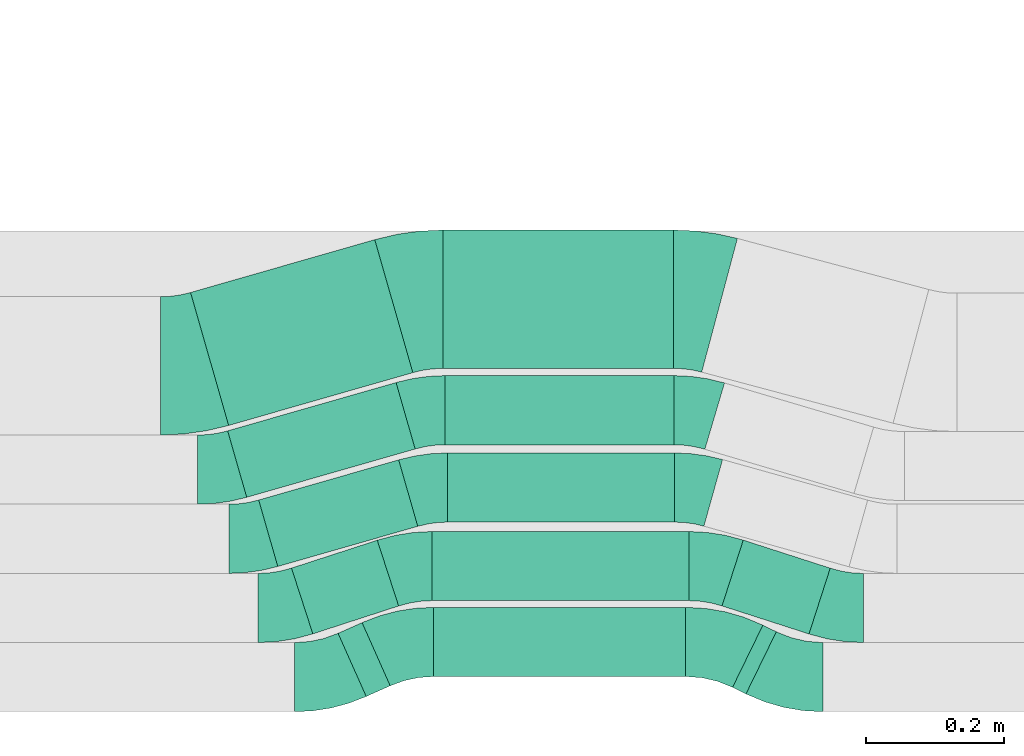
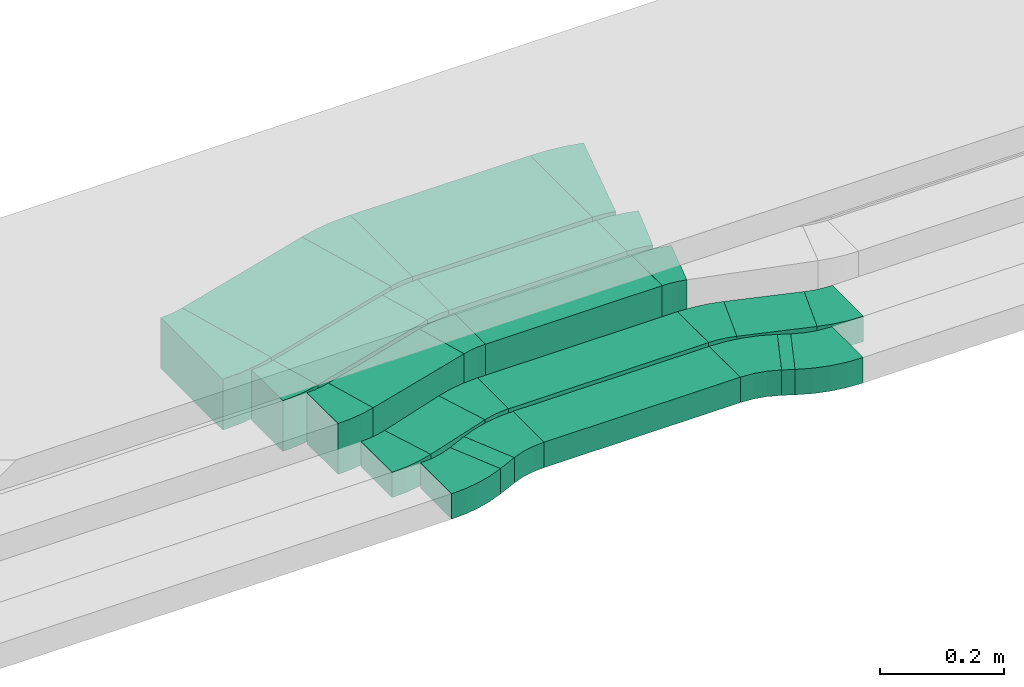
# One storey, part 22 of 38: 17 flow fittings, 12 flow segments.
"""IFC2X3 building model written with IfcOpenShell, lengths in millimetres."""

import ifcopenshell
import ifcopenshell.guid

model = None  # the IFC model being written
_history = None  # IfcOwnerHistory: only IFC2X3 demands one
_inside = {}  # id of a spatial element -> (the spatial element, [elements in it])
_under = {}  # id of a project, library or spatial element -> (it, [spatial elements below it])
_declared = {}  # id of a project -> (the project, [libraries it declares])
_typed = {}  # id of a type object -> (the type object, [elements of that type])
_made_of = {}  # id of a material, layer set ... -> (it, [elements and type objects made of it])


def new_model(schema):
    """Start an empty IFC model of exactly this schema.

    Asked for "IFC4X3", IfcOpenShell would pick the latest addendum, in which some entities
    have other attributes; the version numbers below select the first issue.
    IFC2X3 requires an IfcOwnerHistory on every rooted entity: one is made here for all.
    """
    global model, _history
    if schema == "IFC4X3":
        model = ifcopenshell.file(schema_version=(4, 3, 0, 0))
    else:
        model = ifcopenshell.file(schema=schema)
    _inside.clear()
    _under.clear()
    _declared.clear()
    _typed.clear()
    _made_of.clear()
    _history = None
    if model.schema == "IFC2X3":
        org = make("IfcOrganization", Name="unknown")
        user = make(
            "IfcPersonAndOrganization",
            ThePerson=make("IfcPerson", FamilyName="unknown"),
            TheOrganization=org,
        )
        app = make(
            "IfcApplication",
            ApplicationDeveloper=org,
            Version="unknown",
            ApplicationFullName="unknown",
            ApplicationIdentifier="unknown",
        )
        _history = make(
            "IfcOwnerHistory",
            OwningUser=user,
            OwningApplication=app,
            ChangeAction="ADDED",
            CreationDate=0,
        )
    return model


def make(cls, **values):
    """One entity of the class cls with the attributes given. An attribute that is None is left unset."""
    return model.create_entity(
        cls, **{name: value for name, value in values.items() if value is not None}
    )


def entity(cls, *values):
    """Any entity or typed value of the class cls, its attributes in the order of the schema. None: left unset."""
    e = model.create_entity(cls)
    for i, value in enumerate(values):
        if value is not None:
            e[i] = value
    return e


def rooted(cls, **values):
    """An entity with a GlobalId (a new one), such as an element, a storey or a relation."""
    return make(cls, GlobalId=ifcopenshell.guid.new(), OwnerHistory=_history, **values)


def si_unit(unit_type, name, prefix=None):
    """IfcSIUnit, for example si_unit("LENGTHUNIT", "METRE", prefix="MILLI")."""
    return make("IfcSIUnit", UnitType=unit_type, Prefix=prefix, Name=name)


def converted_unit(unit_type, name, factor, base, dimensions=None, offset=None):
    """IfcConversionBasedUnit, such as the inch: factor (a typed value) times the base unit."""
    return make(
        "IfcConversionBasedUnit"
        if offset is None
        else "IfcConversionBasedUnitWithOffset",
        ConversionOffset=offset,
        Dimensions=None
        if dimensions is None
        else entity("IfcDimensionalExponents", *dimensions),
        UnitType=unit_type,
        Name=name,
        ConversionFactor=make(
            "IfcMeasureWithUnit", ValueComponent=factor, UnitComponent=base
        ),
    )


def derived_unit(unit_type, elements):
    """IfcDerivedUnit: a product of units, each with its exponent."""
    return make(
        "IfcDerivedUnit",
        Elements=[
            make("IfcDerivedUnitElement", Unit=unit, Exponent=power)
            for unit, power in elements
        ],
        UnitType=unit_type,
    )


def assignment(units):
    """IfcUnitAssignment: the units of a project."""
    return None if units is None else make("IfcUnitAssignment", Units=units)


def point(xyz):
    """IfcCartesianPoint."""
    return None if xyz is None else make("IfcCartesianPoint", Coordinates=xyz)


def direction(xyz):
    """IfcDirection."""
    return None if xyz is None else make("IfcDirection", DirectionRatios=xyz)


def frame(location, z_axis=None, x_axis=None):
    """IfcAxis2Placement3D, a coordinate frame: its origin and axes. An axis left out is left unset."""
    return make(
        "IfcAxis2Placement3D",
        Location=point(location),
        Axis=direction(z_axis),
        RefDirection=direction(x_axis),
    )


def frame_2d(location, x_axis=None):
    """IfcAxis2Placement2D, a coordinate frame in the plane: its origin and x axis."""
    return make(
        "IfcAxis2Placement2D", Location=point(location), RefDirection=direction(x_axis)
    )


def origin():
    """The frame at (0, 0, 0) with its axes left unset."""
    return frame((0.0, 0.0, 0.0))


def place(relative_to, where):
    """IfcLocalPlacement: puts the frame where relative to a parent placement (None: the world)."""
    return make(
        "IfcLocalPlacement", PlacementRelTo=relative_to, RelativePlacement=where
    )


def context(
    kind, dimensions, precision=None, world=None, true_north=None, identifier=None
):
    """IfcGeometricRepresentationContext, for example the 3D "Model" context."""
    return make(
        "IfcGeometricRepresentationContext",
        ContextIdentifier=identifier,
        ContextType=kind,
        CoordinateSpaceDimension=dimensions,
        Precision=precision,
        WorldCoordinateSystem=world,
        TrueNorth=true_north,
    )


def subcontext(parent, identifier, kind, view, scale=None):
    """IfcGeometricRepresentationSubContext, for example "Body" below "Model"."""
    return make(
        "IfcGeometricRepresentationSubContext",
        ContextIdentifier=identifier,
        ContextType=kind,
        ParentContext=parent,
        TargetScale=scale,
        TargetView=view,
    )


def project(units=None, contexts=None):
    """IfcProject with its units and contexts."""
    return rooted(
        "IfcProject",
        Name="project",
        RepresentationContexts=contexts,
        UnitsInContext=assignment(units),
    )


def spatial(cls, under=None, at=None, **own):
    """A site, building, storey or space (cls), placed at a placement, below another one or the project."""
    s = rooted(cls, ObjectPlacement=at, **own)
    if under is not None:
        _under.setdefault(under.id(), (under, []))[1].append(s)
    return s


def polyline(points):
    """IfcPolyline through the points."""
    return make("IfcPolyline", Points=[point(p) for p in points])


def circle_curve(where, radius):
    """IfcCircle in the frame where."""
    return make("IfcCircle", Position=where, Radius=radius)


def parameter(value):
    """IfcParameterValue: where a trimmed curve begins or ends, as a parameter of its basis curve."""
    return model.create_entity("IfcParameterValue", value)


def trimmed(basis, trim1, trim2, sense, master):
    """IfcTrimmedCurve: the piece of a basis curve between two trims."""
    return make(
        "IfcTrimmedCurve",
        BasisCurve=basis,
        Trim1=trim1,
        Trim2=trim2,
        SenseAgreement=sense,
        MasterRepresentation=master,
    )


def segment(curve, same_sense, transition):
    """IfcCompositeCurveSegment."""
    return make(
        "IfcCompositeCurveSegment",
        Transition=transition,
        SameSense=same_sense,
        ParentCurve=curve,
    )


def composite_curve(segments, self_intersect=None):
    """IfcCompositeCurve: segments joined end to end."""
    return make("IfcCompositeCurve", Segments=segments, SelfIntersect=self_intersect)


def profile(cls, at=None, kind="AREA", **sizes):
    """A parametric profile (cls). Its sizes go by their IFC names, for example OverallWidth=200.0."""
    return make(cls, ProfileType=kind, Position=at, **sizes)


def rectangle(**sizes):
    """IfcRectangleProfileDef."""
    return profile("IfcRectangleProfileDef", **sizes)


def outline(outer, holes=None, kind="AREA"):
    """IfcArbitraryClosedProfileDef: a profile drawn as a closed curve; with holes, ...WithVoids."""
    if holes is None:
        return make("IfcArbitraryClosedProfileDef", ProfileType=kind, OuterCurve=outer)
    return make(
        "IfcArbitraryProfileDefWithVoids",
        ProfileType=kind,
        OuterCurve=outer,
        InnerCurves=holes,
    )


def extrude(swept, where, along, depth):
    """IfcExtrudedAreaSolid: the profile swept, set in the frame where, extruded along a direction by depth."""
    return make(
        "IfcExtrudedAreaSolid",
        SweptArea=swept,
        Position=where,
        ExtrudedDirection=direction(along),
        Depth=depth,
    )


def shape(context_of_items, identifier, shape_type, items):
    """IfcShapeRepresentation: the items that make up one representation, for example the "Body"."""
    return make(
        "IfcShapeRepresentation",
        ContextOfItems=context_of_items,
        RepresentationIdentifier=identifier,
        RepresentationType=shape_type,
        Items=items,
    )


def source(mapping_origin, context_of_items, identifier, shape_type, items):
    """IfcRepresentationMap: a shape defined once, which mapped items show again and again."""
    return make(
        "IfcRepresentationMap",
        MappingOrigin=mapping_origin,
        MappedRepresentation=shape(context_of_items, identifier, shape_type, items),
    )


def transform(
    local_origin,
    x_axis=None,
    y_axis=None,
    z_axis=None,
    scale=None,
    scale2=None,
    scale3=None,
    uniform=True,
):
    """IfcCartesianTransformationOperator3D, or its non-uniform kind. x_axis, y_axis, z_axis: its Axis1, 2, 3."""
    if uniform:
        return make(
            "IfcCartesianTransformationOperator3D",
            Axis1=direction(x_axis),
            Axis2=direction(y_axis),
            LocalOrigin=point(local_origin),
            Scale=scale,
            Axis3=direction(z_axis),
        )
    return make(
        "IfcCartesianTransformationOperator3DnonUniform",
        Axis1=direction(x_axis),
        Axis2=direction(y_axis),
        LocalOrigin=point(local_origin),
        Scale=scale,
        Axis3=direction(z_axis),
        Scale2=scale2,
        Scale3=scale3,
    )


def mapped(mapping_source, mapping_target):
    """IfcMappedItem: shows the shape of a source again, moved by a transform."""
    return make(
        "IfcMappedItem", MappingSource=mapping_source, MappingTarget=mapping_target
    )


def material(Name=None, Category=None):
    """IfcMaterial."""
    return make("IfcMaterial", Name=Name, Category=Category)


def made_of(thing, what):
    """Note that an element or type object is made of a material, layer set ...; save() writes the relation."""
    if what is not None:
        _made_of.setdefault(what.id(), (what, []))[1].append(thing)
    return thing


def type_object(cls, material=None, **own):
    """A type object (cls), such as IfcWallType, which elements share."""
    return made_of(rooted(cls, **own), material)


def type_shapes(of_type, sources):
    """Give a type object the sources (RepresentationMaps) that its elements show as mapped items."""
    of_type.RepresentationMaps = sources


def element(
    cls,
    number,
    at=None,
    inside=None,
    cuts=None,
    type_object=None,
    material=None,
    context=None,
    identifier="Body",
    shape_type=None,
    held_by="IfcProductDefinitionShape",
    body=None,
    shapes=None,
    **own,
):
    """One element of the class cls, such as IfcWall. Its Tag is "e" and its number.

    at: its placement. inside: the storey or other place that contains it. cuts: it is an
    opening in that element (IfcRelVoidsElement). A single representation is given by context,
    identifier, shape_type and body (its items); several are given by shapes. held_by: the class
    of the entity that holds the representations. save() writes the other relations.
    """
    e = rooted(cls, Tag="e%d" % number, ObjectPlacement=at, **own)
    if body is not None:
        shapes = [shape(context, identifier, shape_type, body)]
    if shapes is not None:
        e.Representation = make(held_by, Representations=shapes)
    if inside is not None:
        _inside.setdefault(inside.id(), (inside, []))[1].append(e)
    if cuts is not None:
        rooted(
            "IfcRelVoidsElement", RelatingBuildingElement=cuts, RelatedOpeningElement=e
        )
    if type_object is not None:
        _typed.setdefault(type_object.id(), (type_object, []))[1].append(e)
    return made_of(e, material)


def aggregate(whole, parts):
    """IfcRelAggregates: a whole, such as a stair, and the parts it consists of."""
    return rooted("IfcRelAggregates", RelatingObject=whole, RelatedObjects=parts)


def save(model, path):
    """Write the relations noted so far, then the file.

    IfcRelAggregates (storeys below a building ...), IfcRelContainedInSpatialStructure (elements
    in a storey), IfcRelDefinesByType, IfcRelAssociatesMaterial and IfcRelDeclares: one each for
    every whole, place, type object, material and project.
    """
    for whole, parts in _under.values():
        aggregate(whole, parts)
    for where, things in _inside.values():
        rooted(
            "IfcRelContainedInSpatialStructure",
            RelatedElements=things,
            RelatingStructure=where,
        )
    for kind, things in _typed.values():
        rooted("IfcRelDefinesByType", RelatedObjects=things, RelatingType=kind)
    for what, things in _made_of.values():
        rooted("IfcRelAssociatesMaterial", RelatedObjects=things, RelatingMaterial=what)
    for by, libraries in _declared.values():
        rooted("IfcRelDeclares", RelatingContext=by, RelatedDefinitions=libraries)
    model.write(path)


model = new_model("IFC2X3")

# Units and contexts
model_context = context("Model", 3, precision=0.01, world=origin(), true_north=direction((6.12303176911189e-17, 1.0)))
body_context = subcontext(model_context, "Body", "Model", "MODEL_VIEW")
ifc_project = project(units=[si_unit("LENGTHUNIT", "METRE", prefix="MILLI"), si_unit("AREAUNIT", "SQUARE_METRE"), si_unit("VOLUMEUNIT", "CUBIC_METRE"), converted_unit("PLANEANGLEUNIT", "DEGREE", entity("IfcRatioMeasure", 0.0174532925199433), si_unit("PLANEANGLEUNIT", "RADIAN"), dimensions=[0, 0, 0, 0, 0, 0, 0]), si_unit("MASSUNIT", "GRAM", prefix="KILO"), derived_unit("MASSDENSITYUNIT", [(si_unit("MASSUNIT", "GRAM", prefix="KILO"), 1), (si_unit("LENGTHUNIT", "METRE"), -3)]), derived_unit("MOMENTOFINERTIAUNIT", [(si_unit("LENGTHUNIT", "METRE"), 4)]), si_unit("TIMEUNIT", "SECOND"), si_unit("FREQUENCYUNIT", "HERTZ"), si_unit("THERMODYNAMICTEMPERATUREUNIT", "DEGREE_CELSIUS"), derived_unit("THERMALTRANSMITTANCEUNIT", [(si_unit("MASSUNIT", "GRAM", prefix="KILO"), 1), (si_unit("THERMODYNAMICTEMPERATUREUNIT", "KELVIN"), -1), (si_unit("TIMEUNIT", "SECOND"), -3)]), derived_unit("VOLUMETRICFLOWRATEUNIT", [(si_unit("LENGTHUNIT", "METRE"), 3), (si_unit("TIMEUNIT", "SECOND"), -1)]), derived_unit("MASSFLOWRATEUNIT", [(si_unit("MASSUNIT", "GRAM", prefix="KILO"), 1), (si_unit("TIMEUNIT", "SECOND"), -1)]), derived_unit("ROTATIONALFREQUENCYUNIT", [(si_unit("TIMEUNIT", "SECOND"), -1)]), si_unit("ELECTRICCURRENTUNIT", "AMPERE"), si_unit("ELECTRICVOLTAGEUNIT", "VOLT"), si_unit("POWERUNIT", "WATT"), si_unit("FORCEUNIT", "NEWTON", prefix="KILO"), si_unit("ILLUMINANCEUNIT", "LUX"), si_unit("LUMINOUSFLUXUNIT", "LUMEN"), si_unit("LUMINOUSINTENSITYUNIT", "CANDELA"), derived_unit("USERDEFINED", [(si_unit("MASSUNIT", "GRAM", prefix="KILO"), -1), (si_unit("LENGTHUNIT", "METRE"), -2), (si_unit("TIMEUNIT", "SECOND"), 3), (si_unit("LUMINOUSFLUXUNIT", "LUMEN"), 1)]), derived_unit("LINEARVELOCITYUNIT", [(si_unit("LENGTHUNIT", "METRE"), 1), (si_unit("TIMEUNIT", "SECOND"), -1)]), si_unit("PRESSUREUNIT", "PASCAL"), derived_unit("USERDEFINED", [(si_unit("LENGTHUNIT", "METRE"), -2), (si_unit("MASSUNIT", "GRAM", prefix="KILO"), 1), (si_unit("TIMEUNIT", "SECOND"), -2)]), derived_unit("LINEARFORCEUNIT", [(si_unit("MASSUNIT", "GRAM", prefix="KILO"), 1), (si_unit("LENGTHUNIT", "METRE"), 1), (si_unit("TIMEUNIT", "SECOND"), -2), (si_unit("LENGTHUNIT", "METRE"), -1)]), derived_unit("PLANARFORCEUNIT", [(si_unit("MASSUNIT", "GRAM", prefix="KILO"), 1), (si_unit("LENGTHUNIT", "METRE"), 1), (si_unit("TIMEUNIT", "SECOND"), -2), (si_unit("LENGTHUNIT", "METRE"), -2)])], contexts=[model_context])

# Site, building, storey
site_placement = place(None, frame((0.0, -0.00077364408347762, 0.0)))
site = spatial("IfcSite", under=ifc_project, at=site_placement, CompositionType="ELEMENT")
building_placement = place(site_placement, origin())
building = spatial("IfcBuilding", under=site, at=building_placement, CompositionType="ELEMENT")
storey_placement = place(building_placement, frame((0.0, 0.0, 4200.0)))
storey = spatial("IfcBuildingStorey", under=building, at=storey_placement, CompositionType="ELEMENT", Elevation=4200.0)

# Flow segments
cable_carrier_segment_type = type_object("IfcCableCarrierSegmentType", PredefinedType="CABLETRAYSEGMENT")
flow_segment_1_placement = place(storey_placement, frame((34682.2954440564, 268.677374504435, 2836.0)))
element("IfcFlowSegment", 1, at=flow_segment_1_placement, inside=storey, type_object=cable_carrier_segment_type, context=body_context, shape_type="SweptSolid", body=[
    extrude(rectangle(XDim=37.9773753319745, YDim=100.000000000002, at=frame_2d((3.96305210870196e-12, -1.74793512996985e-12), x_axis=(1.0, 0.0))), frame((37.6838615176679, 53.4006679598074, 0.0), z_axis=(0.0, 0.0, 1.0), x_axis=(0.913545457642342, 0.406736643076381, 0.0)), (0.0, 0.0, 1.0), 49.9999999999995),
])
flow_segment_2_placement = place(storey_placement, frame((34820.5872090108, 297.499082656489, 2836.0)))
element("IfcFlowSegment", 2, at=flow_segment_2_placement, inside=storey, type_object=cable_carrier_segment_type, context=body_context, shape_type="SweptSolid", body=[
    extrude(rectangle(XDim=364.315049440889, YDim=100.0, at=frame_2d((0.0, -3.19744231092045e-14), x_axis=(1.0, 0.0))), frame((182.157524720444, 50.0, 0.0)), (0.0, 0.0, 1.0), 49.9999999999995),
])
flow_segment_3_placement = place(storey_placement, frame((35252.5567245163, 272.396861844019, 2836.0)))
element("IfcFlowSegment", 3, at=flow_segment_3_placement, inside=storey, type_object=cable_carrier_segment_type, context=body_context, shape_type="SweptSolid", body=[
    extrude(rectangle(XDim=21.632255407363, YDim=99.9999999999977, at=frame_2d((-1.94066984704477e-12, -9.66338120633736e-13), x_axis=(1.0, 0.0))), frame((31.6400285235472, 49.6811806202314, 0.0), z_axis=(0.0, 0.0, 1.0), x_axis=(-0.898794046298938, 0.438371146789548, 0.0)), (0.0, 0.0, 1.0), 49.9999999999995),
])
flow_segment_4_placement = place(storey_placement, frame((34614.9489776385, 359.201890192537, 2836.0)))
element("IfcFlowSegment", 4, at=flow_segment_4_placement, inside=storey, type_object=cable_carrier_segment_type, context=body_context, shape_type="SweptSolid", body=[
    extrude(rectangle(XDim=130.375714038921, YDim=100.0, at=frame_2d((-7.105427357601e-15, -2.8421709430404e-14), x_axis=(1.0, 0.0))), frame((77.4481859204265, 67.696981460663, 0.0), z_axis=(0.0, 0.0, 1.0), x_axis=(0.951056516295102, 0.309016994375106, 0.0)), (0.0, 0.0, 1.0), 49.9999999999995),
])
flow_segment_5_placement = place(storey_placement, frame((34818.1489551518, 407.140741034452, 2836.0)))
element("IfcFlowSegment", 5, at=flow_segment_5_placement, inside=storey, type_object=cable_carrier_segment_type, context=body_context, shape_type="SweptSolid", body=[
    extrude(rectangle(XDim=371.2003762548, YDim=100.0, at=frame_2d((0.0, -3.19744231092045e-14), x_axis=(1.0, 0.0))), frame((185.6001881274, 50.0, 0.0)), (0.0, 0.0, 1.0), 49.9999999999995),
])
flow_segment_6_placement = place(storey_placement, frame((35237.3479071855, 359.034914354499, 2836.0)))
element("IfcFlowSegment", 6, at=flow_segment_6_placement, inside=storey, type_object=cable_carrier_segment_type, context=body_context, shape_type="SweptSolid", body=[
    extrude(rectangle(XDim=132.114181843629, YDim=99.9999999999975, at=frame_2d((1.4210854715202e-14, -2.8421709430404e-14), x_axis=(1.0, 0.0))), frame((78.2165612123092, 67.8639572987042, 0.0), z_axis=(0.0, 0.0, 1.0), x_axis=(-0.951716267923426, 0.306979063406458, 0.0)), (0.0, 0.0, 1.0), 49.9999999999995),
])
flow_segment_7_placement = place(storey_placement, frame((34567.5571030409, 456.617215643251, 2836.0)))
element("IfcFlowSegment", 7, at=flow_segment_7_placement, inside=storey, type_object=cable_carrier_segment_type, context=body_context, shape_type="SweptSolid", body=[
    extrude(rectangle(XDim=210.504113333605, YDim=100.000000000001, at=frame_2d((-2.1316282072803e-14, -6.3948846218409e-14), x_axis=(1.0, 0.0))), frame((114.956638283379, 77.0744833908625, 0.0), z_axis=(0.0, 0.0, 1.0), x_axis=(0.961261695938295, 0.275637355817084, 0.0)), (0.0, 0.0, 1.0), 100.000000000001),
])
flow_segment_8_placement = place(storey_placement, frame((34840.7772446761, 520.726395796214, 2836.0)))
element("IfcFlowSegment", 8, at=flow_segment_8_placement, inside=storey, type_object=cable_carrier_segment_type, context=body_context, shape_type="SweptSolid", body=[
    extrude(rectangle(XDim=328.015010459565, YDim=100.0, at=frame_2d((2.17426077142591e-12, -6.75015598972095e-14), x_axis=(1.0, 0.0))), frame((164.007505229785, 50.0, 0.0)), (0.0, 0.0, 1.0), 100.000000000001),
])
flow_segment_9_placement = place(storey_placement, frame((34522.6611141016, 556.617215643282, 2836.0)))
element("IfcFlowSegment", 9, at=flow_segment_9_placement, inside=storey, type_object=cable_carrier_segment_type, context=body_context, shape_type="SweptSolid", body=[
    extrude(rectangle(XDim=253.294448744535, YDim=99.9999999999999, at=frame_2d((2.08189021577709e-12, -5.89750470680883e-13), x_axis=(1.0, 0.0))), frame((135.522993476812, 82.971790844471, 0.0), z_axis=(0.0, 0.0, 1.0), x_axis=(0.961261695938265, 0.275637355817187, 0.0)), (0.0, 0.0, 1.0), 100.000000000001),
])
flow_segment_10_placement = place(storey_placement, frame((34837.0139661237, 632.521010703464, 2836.0)))
element("IfcFlowSegment", 10, at=flow_segment_10_placement, inside=storey, type_object=cable_carrier_segment_type, context=body_context, shape_type="SweptSolid", body=[
    extrude(rectangle(XDim=331.015908531008, YDim=100.0, at=frame_2d((2.17426077142591e-12, 0.0), x_axis=(1.0, 0.0))), frame((165.507954265502, 50.0, 0.0)), (0.0, 0.0, 1.0), 100.000000000001),
])
flow_segment_11_placement = place(storey_placement, frame((34468.9939164237, 660.49104604952, 2836.0)))
element("IfcFlowSegment", 11, at=flow_segment_11_placement, inside=storey, type_object=cable_carrier_segment_type, context=body_context, shape_type="SweptSolid", body=[
    extrude(rectangle(XDim=277.030700685204, YDim=200.000000000003, at=frame_2d((-2.06057393370429e-12, 6.46593889541691e-13), x_axis=(1.0, 0.0))), frame((160.713236165529, 134.306174502351, 0.0), z_axis=(0.0, 0.0, 1.0), x_axis=(0.961261695938271, 0.275637355817165, 0.0)), (0.0, 0.0, 1.0), 100.000000000001),
])
flow_segment_12_placement = place(storey_placement, frame((34833.7272538232, 742.937438831638, 2836.0)))
element("IfcFlowSegment", 12, at=flow_segment_12_placement, inside=storey, type_object=cable_carrier_segment_type, context=body_context, shape_type="SweptSolid", body=[
    extrude(rectangle(XDim=333.654743209258, YDim=200.0, at=frame_2d((0.0, 6.3948846218409e-14), x_axis=(1.0, 0.0))), frame((166.827371604629, 100.0, 0.0)), (0.0, 0.0, 1.0), 100.000000000001),
])

# Flow fittings
ifc_material = material()
cable_carrier_fitting_type_1 = type_object("IfcCableCarrierFittingType", Name="470_DKC_S5_Variable Angle Elbow 0-45:-", PredefinedType="NOTDEFINED", material=ifc_material)
shared_shape_1 = source(origin(), body_context, "Body", "SweptSolid", [
    extrude(outline(composite_curve([segment(polyline([(-28.5540510056852, -53.9427397451227), (-27.5540510056839, -53.9427397451227)]), True, "CONTINUOUS"), segment(trimmed(circle_curve(frame_2d((-27.5540510056865, 196.057260254877), x_axis=(0.0, -1.0)), 250.0), [parameter(0.0)], [parameter(16.0000000000001)], True, "PARAMETER"), True, "CONTINUOUS"), segment(polyline([(41.3552879485661, -44.2581637297016), (42.3165496445045, -43.9825263738845)]), True, "CONTINUOUS"), segment(polyline([(42.3165496445045, -43.9825263738846), (14.7528140628032, 52.1436432199469)]), True, "CONTINUOUS"), segment(polyline([(14.7528140628032, 52.1436432199469), (13.791552366865, 51.8680058641299)]), True, "CONTINUOUS"), segment(trimmed(circle_curve(frame_2d((-27.5540510056865, 196.057260254877), x_axis=(0.0, -1.0)), 150.0), [parameter(0.0)], [parameter(16.0000000000001)], True, "PARAMETER"), False, "CONTINUOUS"), segment(polyline([(-27.5540510056847, 46.0572602548772), (-28.5540510056861, 46.0572602548772)]), True, "CONTINUOUS"), segment(polyline([(-28.5540510056861, 46.0572602548772), (-28.5540510056852, -53.9427397451227)]), True, "CONTINUOUS")], self_intersect=False)), frame((-0.554115934784018, 3.94273974511436, -50.0)), (0.0, 0.0, 1.0), 100.0),
])
type_shapes(cable_carrier_fitting_type_1, [shared_shape_1])
flow_fitting_1_placement = place(storey_placement, frame((34553.3584049129, 496.65700227203, 2886.0)))
element("IfcFlowFitting", 13, at=flow_fitting_1_placement, inside=storey, type_object=cable_carrier_fitting_type_1, material=ifc_material, Name="470_DKC_S5_Variable Angle Elbow 0-45:-", ObjectType="470_DKC_S5_Variable Angle Elbow 0-45:-", context=body_context, shape_type="MappedRepresentation", body=[
    mapped(shared_shape_1, transform((0.0, 0.0, 0.0), scale=1.0)),
])
flow_fitting_2_placement = place(storey_placement, frame((34811.6690777356, 570.726395796198, 2886.0), z_axis=(0.0, 0.0, 1.0), x_axis=(-1.0, 0.0, 0.0)))
element("IfcFlowFitting", 14, at=flow_fitting_2_placement, inside=storey, type_object=cable_carrier_fitting_type_1, material=ifc_material, Name="470_DKC_S5_Variable Angle Elbow 0-45:-", ObjectType="470_DKC_S5_Variable Angle Elbow 0-45:-", context=body_context, shape_type="MappedRepresentation", body=[
    mapped(shared_shape_1, transform((0.0, 0.0, 0.0), scale=1.0)),
])
flow_fitting_3_placement = place(storey_placement, frame((34508.4624159736, 596.657002272058, 2886.0)))
element("IfcFlowFitting", 15, at=flow_fitting_3_placement, inside=storey, type_object=cable_carrier_fitting_type_1, material=ifc_material, Name="470_DKC_S5_Variable Angle Elbow 0-45:-", ObjectType="470_DKC_S5_Variable Angle Elbow 0-45:-", context=body_context, shape_type="MappedRepresentation", body=[
    mapped(shared_shape_1, transform((0.0, 0.0, 0.0), scale=1.0)),
])
flow_fitting_4_placement = place(storey_placement, frame((34807.9057991832, 682.521010703447, 2886.0), z_axis=(0.0, 0.0, 1.0), x_axis=(-1.0, 0.0, 0.0)))
element("IfcFlowFitting", 16, at=flow_fitting_4_placement, inside=storey, type_object=cable_carrier_fitting_type_1, material=ifc_material, Name="470_DKC_S5_Variable Angle Elbow 0-45:-", ObjectType="470_DKC_S5_Variable Angle Elbow 0-45:-", context=body_context, shape_type="MappedRepresentation", body=[
    mapped(shared_shape_1, transform((0.0, 0.0, 0.0), scale=1.0)),
])
cable_carrier_fitting_type_2 = type_object("IfcCableCarrierFittingType", Name="470_DKC_S5_Variable Angle Elbow 0-45:-", PredefinedType="NOTDEFINED", material=ifc_material)
shared_shape_2 = source(origin(), body_context, "Body", "SweptSolid", [
    extrude(outline(composite_curve([segment(polyline([(-41.6520506719925, -58.7471383965093), (-40.6520506719912, -58.7471383965093)]), True, "CONTINUOUS"), segment(trimmed(circle_curve(frame_2d((-40.6520506719917, 191.25286160349), x_axis=(0.0, -1.0)), 250.0), [parameter(0.0)], [parameter(24.0000000000006)], True, "PARAMETER"), True, "CONTINUOUS"), segment(polyline([(61.0321100969608, -37.1335028071584), (61.9456555546033, -36.7267661640826)]), True, "CONTINUOUS"), segment(polyline([(61.9456555546033, -36.7267661640827), (21.2719912470226, 54.627779600177)]), True, "CONTINUOUS"), segment(polyline([(21.2719912470226, 54.627779600177), (20.3584457893798, 54.2210429571011)]), True, "CONTINUOUS"), segment(trimmed(circle_curve(frame_2d((-40.6520506719917, 191.25286160349), x_axis=(0.0, -1.0)), 150.0), [parameter(0.0)], [parameter(24.0000000000006)], True, "PARAMETER"), False, "CONTINUOUS"), segment(polyline([(-40.6520506719912, 41.2528616034906), (-41.6520506719925, 41.2528616034906)]), True, "CONTINUOUS"), segment(polyline([(-41.6520506719925, 41.2528616034906), (-41.6520506719925, -58.7471383965093)]), True, "CONTINUOUS")], self_intersect=False)), frame((-1.85926166200414, 8.74713839650124, -25.0)), (0.0, 0.0, 1.0), 50.0),
])
type_shapes(cable_carrier_fitting_type_2, [shared_shape_2])
flow_fitting_5_placement = place(storey_placement, frame((34662.8827144714, 296.657002272014, 2861.0)))
element("IfcFlowFitting", 17, at=flow_fitting_5_placement, inside=storey, type_object=cable_carrier_fitting_type_2, material=ifc_material, Name="470_DKC_S5_Variable Angle Elbow 0-45:-", ObjectType="470_DKC_S5_Variable Angle Elbow 0-45:-", context=body_context, shape_type="MappedRepresentation", body=[
    mapped(shared_shape_2, transform((0.0, 0.0, 0.0), scale=1.0)),
])
flow_fitting_6_placement = place(storey_placement, frame((34777.0758966768, 347.499082656472, 2861.0), z_axis=(0.0, 0.0, 1.0), x_axis=(-1.0, 0.0, 0.0)))
element("IfcFlowFitting", 18, at=flow_fitting_6_placement, inside=storey, type_object=cable_carrier_fitting_type_2, material=ifc_material, Name="470_DKC_S5_Variable Angle Elbow 0-45:-", ObjectType="470_DKC_S5_Variable Angle Elbow 0-45:-", context=body_context, shape_type="MappedRepresentation", body=[
    mapped(shared_shape_2, transform((0.0, 0.0, 0.0), scale=1.0)),
])
cable_carrier_fitting_type_3 = type_object("IfcCableCarrierFittingType", Name="470_DKC_S5_Variable Angle Elbow 0-45:-", PredefinedType="NOTDEFINED", material=ifc_material)
shared_shape_3 = source(origin(), body_context, "Body", "SweptSolid", [
    extrude(outline(composite_curve([segment(polyline([(-44.8118131904836, -60.2301881567807), (-43.8118131904823, -60.2301881567807)]), True, "CONTINUOUS"), segment(trimmed(circle_curve(frame_2d((-43.8118131904828, 189.769811843219), x_axis=(0.0, -1.0)), 250.0), [parameter(0.0)], [parameter(26.0000000000001)], True, "PARAMETER"), True, "CONTINUOUS"), segment(polyline([(65.7809735067871, -34.9286997315721), (66.6797675530858, -34.4903285847833)]), True, "CONTINUOUS"), segment(polyline([(66.6797675530858, -34.4903285847833), (22.8426528741789, 55.3890760451337)]), True, "CONTINUOUS"), segment(polyline([(22.8426528741789, 55.3890760451337), (21.9438588278792, 54.9507048983444)]), True, "CONTINUOUS"), segment(trimmed(circle_curve(frame_2d((-43.8118131904828, 189.769811843219), x_axis=(0.0, -1.0)), 150.0), [parameter(0.0)], [parameter(26.0000000000001)], True, "PARAMETER"), False, "CONTINUOUS"), segment(polyline([(-43.8118131904823, 39.7698118432192), (-44.8118131904836, 39.7698118432192)]), True, "CONTINUOUS"), segment(polyline([(-44.8118131904836, 39.7698118432192), (-44.8118131904836, -60.2301881567807)]), True, "CONTINUOUS")], self_intersect=False)), frame((-2.36182503462038, 10.2301881567726, -25.0)), (0.0, 0.0, 1.0), 50.0),
])
type_shapes(cable_carrier_fitting_type_3, [shared_shape_3])
for number, where, z_axis, x_axis, name in (
    (19, (35336.3176094029, 296.657002272025, 2861.0), (0.0, 0.0, 1.0), (0.898794046299104, -0.438371146789206, 0.0), "470_DKC_S5_Variable Angle Elbow 0-45:-"),
    (20, (35232.0758966768, 347.499082656481, 2861.0), (0.0, 0.0, 1.0), (-0.898794046298929, 0.438371146789566, 0.0), "470_DKC_S5_Variable Angle Elbow 0-45:-"),
):
    element("IfcFlowFitting", number, at=place(storey_placement, frame(where, z_axis=z_axis, x_axis=x_axis)), inside=storey, type_object=cable_carrier_fitting_type_3, material=ifc_material, Name=name, ObjectType="470_DKC_S5_Variable Angle Elbow 0-45:-", context=body_context, shape_type="MappedRepresentation", body=[
        mapped(shared_shape_3, transform((0.0, 0.0, 0.0), scale=1.0)),
    ])
cable_carrier_fitting_type_4 = type_object("IfcCableCarrierFittingType", Name="470_DKC_S5_Variable Angle Elbow 0-45:-", PredefinedType="NOTDEFINED", material=ifc_material)
shared_shape_4 = source(origin(), body_context, "Body", "SweptSolid", [
    extrude(outline(composite_curve([segment(polyline([(-31.8894635665696, -54.9716026190784), (-30.8894635665683, -54.9716026190784)]), True, "CONTINUOUS"), segment(trimmed(circle_curve(frame_2d((-30.8894635665687, 195.028397380921), x_axis=(0.0, -1.0)), 250.0), [parameter(0.0)], [parameter(18.0)], True, "PARAMETER"), True, "CONTINUOUS"), segment(polyline([(46.3647850271685, -42.7357316928666), (47.3158415434637, -42.4267146984917)]), True, "CONTINUOUS"), segment(polyline([(47.3158415434637, -42.4267146984917), (16.4141421059688, 52.6789369310235)]), True, "CONTINUOUS"), segment(polyline([(16.4141421059688, 52.6789369310235), (15.4630855896736, 52.3699199366485)]), True, "CONTINUOUS"), segment(trimmed(circle_curve(frame_2d((-30.8894635665687, 195.028397380921), x_axis=(0.0, -1.0)), 150.0), [parameter(0.0)], [parameter(18.0)], True, "PARAMETER"), False, "CONTINUOUS"), segment(polyline([(-30.8894635665683, 45.0283973809215), (-31.8894635665696, 45.0283973809215)]), True, "CONTINUOUS"), segment(polyline([(-31.8894635665696, 45.0283973809215), (-31.8894635665696, -54.9716026190784)]), True, "CONTINUOUS")], self_intersect=False)), frame((-0.787424498328967, 4.97160261907036, -25.0)), (0.0, 0.0, 1.0), 50.0000000000001),
])
type_shapes(cable_carrier_fitting_type_4, [shared_shape_4])
flow_fitting_7_placement = place(storey_placement, frame((34599.3222600308, 396.657002271965, 2861.0)))
element("IfcFlowFitting", 21, at=flow_fitting_7_placement, inside=storey, type_object=cable_carrier_fitting_type_4, material=ifc_material, Name="470_DKC_S5_Variable Angle Elbow 0-45:-", ObjectType="470_DKC_S5_Variable Angle Elbow 0-45:-", context=body_context, shape_type="MappedRepresentation", body=[
    mapped(shared_shape_4, transform((0.0, 0.0, 0.0), scale=1.0)),
])
flow_fitting_8_placement = place(storey_placement, frame((34785.4720670869, 457.140741034436, 2861.0), z_axis=(0.0, 0.0, 1.0), x_axis=(-1.0, 0.0, 0.0)))
element("IfcFlowFitting", 22, at=flow_fitting_8_placement, inside=storey, type_object=cable_carrier_fitting_type_4, material=ifc_material, Name="470_DKC_S5_Variable Angle Elbow 0-45:-", ObjectType="470_DKC_S5_Variable Angle Elbow 0-45:-", context=body_context, shape_type="MappedRepresentation", body=[
    mapped(shared_shape_4, transform((0.0, 0.0, 0.0), scale=1.0)),
])
cable_carrier_fitting_type_5 = type_object("IfcCableCarrierFittingType", Name="470_DKC_S5_Variable Angle Elbow 0-45:-", PredefinedType="NOTDEFINED", material=ifc_material)
shared_shape_5 = source(origin(), body_context, "Body", "SweptSolid", [
    extrude(outline(composite_curve([segment(polyline([(-31.6858354076099, -54.9051179735033), (-30.6858354076085, -54.9051179735033)]), True, "CONTINUOUS"), segment(trimmed(circle_curve(frame_2d((-30.685835407609, 195.094882026496), x_axis=(0.0, -1.0)), 250.0), [parameter(0.0)], [parameter(17.8772687945037)], True, "PARAMETER"), True, "CONTINUOUS"), segment(polyline([(46.0589304439612, -42.834184954374), (47.0106467118846, -42.5272058909677)]), True, "CONTINUOUS"), segment(polyline([(47.0106467118846, -42.5272058909678), (16.3127403712567, 52.6444209013805)]), True, "CONTINUOUS"), segment(polyline([(16.3127403712567, 52.6444209013805), (15.3610241033331, 52.3374418379742)]), True, "CONTINUOUS"), segment(trimmed(circle_curve(frame_2d((-30.685835407609, 195.094882026496), x_axis=(0.0, -1.0)), 150.0), [parameter(0.0)], [parameter(17.8772687945037)], True, "PARAMETER"), False, "CONTINUOUS"), segment(polyline([(-30.6858354076085, 45.0948820264966), (-31.6858354076099, 45.0948820264966)]), True, "CONTINUOUS"), segment(polyline([(-31.6858354076099, 45.0948820264966), (-31.6858354076099, -54.9051179735033)]), True, "CONTINUOUS")], self_intersect=False)), frame((-0.771509950565862, 4.90511797349519, -25.0)), (0.0, 0.0, 1.0), 50.0000000000001),
])
type_shapes(cable_carrier_fitting_type_5, [shared_shape_5])
for number, where, z_axis, x_axis, name in (
    (23, (35409.3222600308, 396.657002271979, 2861.0), (0.0, 0.0, 1.0), (0.951716267923469, -0.306979063406325, 0.0), "470_DKC_S5_Variable Angle Elbow 0-45:-"),
    (24, (35221.8066767648, 457.140741034429, 2861.0), (0.0, 0.0, 1.0), (-0.951716267923451, 0.30697906340638, 0.0), "470_DKC_S5_Variable Angle Elbow 0-45:-"),
):
    element("IfcFlowFitting", number, at=place(storey_placement, frame(where, z_axis=z_axis, x_axis=x_axis)), inside=storey, type_object=cable_carrier_fitting_type_5, material=ifc_material, Name=name, ObjectType="470_DKC_S5_Variable Angle Elbow 0-45:-", context=body_context, shape_type="MappedRepresentation", body=[
        mapped(shared_shape_5, transform((0.0, 0.0, 0.0), scale=1.0)),
    ])
cable_carrier_fitting_type_6 = type_object("IfcCableCarrierFittingType", Name="470_DKC_S5_Variable Angle Elbow 0-45:-", PredefinedType="NOTDEFINED", material=ifc_material)
shared_shape_6 = source(origin(), body_context, "Body", "SweptSolid", [
    extrude(outline(composite_curve([segment(polyline([(-27.9511371539973, -53.7702715501628), (-26.951137153996, -53.7702715501628)]), True, "CONTINUOUS"), segment(trimmed(circle_curve(frame_2d((-26.9511371539986, 196.229728449837), x_axis=(0.0, -1.0)), 250.0), [parameter(0.0)], [parameter(15.6407005368424)], True, "PARAMETER"), True, "CONTINUOUS"), segment(polyline([(40.4498486720227, -44.5130951393208), (41.4128199663793, -44.2434911960168)]), True, "CONTINUOUS"), segment(polyline([(41.4128199663793, -44.2434911960168), (14.4524256359709, 52.0536382396464)]), True, "CONTINUOUS"), segment(polyline([(14.4524256359709, 52.0536382396464), (13.4894543416142, 51.7840342963423)]), True, "CONTINUOUS"), segment(trimmed(circle_curve(frame_2d((-26.9511371539986, 196.229728449837), x_axis=(0.0, -1.0)), 150.0), [parameter(0.0)], [parameter(15.6407005368424)], True, "PARAMETER"), False, "CONTINUOUS"), segment(polyline([(-26.9511371539968, 46.2297284498371), (-27.9511371539982, 46.2297284498371)]), True, "CONTINUOUS"), segment(polyline([(-27.9511371539982, 46.2297284498371), (-27.9511371539973, -53.7702715501628)]), True, "CONTINUOUS")], self_intersect=False)), frame((-0.517827275495085, 3.77027155015447, -50.0)), (0.0, 0.0, 1.0), 100.0),
])
type_shapes(cable_carrier_fitting_type_6, [shared_shape_6])
flow_fitting_9_placement = place(storey_placement, frame((35197.2612195652, 570.726395796193, 2886.0), z_axis=(0.0, 0.0, 1.0), x_axis=(-0.962971294356617, 0.269603943304141, 0.0)))
element("IfcFlowFitting", 25, at=flow_fitting_9_placement, inside=storey, type_object=cable_carrier_fitting_type_6, material=ifc_material, Name="470_DKC_S5_Variable Angle Elbow 0-45:-", ObjectType="470_DKC_S5_Variable Angle Elbow 0-45:-", context=body_context, shape_type="MappedRepresentation", body=[
    mapped(shared_shape_6, transform((0.0, 0.0, 0.0), scale=1.0)),
])
cable_carrier_fitting_type_7 = type_object("IfcCableCarrierFittingType", Name="470_DKC_S5_Variable Angle Elbow 0-45:-", PredefinedType="NOTDEFINED", material=ifc_material)
shared_shape_7 = source(origin(), body_context, "Body", "SweptSolid", [
    extrude(outline(composite_curve([segment(polyline([(-29.3870557848613, -54.1877798191967), (-28.38705578486, -54.1877798191967)]), True, "CONTINUOUS"), segment(trimmed(circle_curve(frame_2d((-28.3870557848626, 195.812220180803), x_axis=(0.0, -1.0)), 250.0), [parameter(0.0)], [parameter(16.4974981762259)], True, "PARAMETER"), True, "CONTINUOUS"), segment(polyline([(42.606313592603, -43.8958136946485), (43.5651457281047, -43.6118402171386)]), True, "CONTINUOUS"), segment(polyline([(43.5651457281047, -43.6118402171387), (15.1677979771187, 52.271373333042)]), True, "CONTINUOUS"), segment(polyline([(15.1677979771187, 52.271373333042), (14.2089658416168, 51.9873998555321)]), True, "CONTINUOUS"), segment(trimmed(circle_curve(frame_2d((-28.3870557848626, 195.812220180803), x_axis=(0.0, -1.0)), 150.0), [parameter(0.0)], [parameter(16.4974981762259)], True, "PARAMETER"), False, "CONTINUOUS"), segment(polyline([(-28.3870557848609, 45.8122201808031), (-29.3870557848622, 45.8122201808031)]), True, "CONTINUOUS"), segment(polyline([(-29.3870557848622, 45.8122201808031), (-29.3870557848613, -54.1877798191967)]), True, "CONTINUOUS")], self_intersect=False)), frame((-0.607105824297182, 4.18777981918844, -50.0)), (0.0, 0.0, 1.0), 100.0),
])
type_shapes(cable_carrier_fitting_type_7, [shared_shape_7])
flow_fitting_10_placement = place(storey_placement, frame((35198.0240362639, 682.521010703457, 2886.0), z_axis=(0.0, 0.0, 1.0), x_axis=(-0.95883213550181, 0.283973477509853, 0.0)))
element("IfcFlowFitting", 26, at=flow_fitting_10_placement, inside=storey, type_object=cable_carrier_fitting_type_7, material=ifc_material, Name="470_DKC_S5_Variable Angle Elbow 0-45:-", ObjectType="470_DKC_S5_Variable Angle Elbow 0-45:-", context=body_context, shape_type="MappedRepresentation", body=[
    mapped(shared_shape_7, transform((0.0, 0.0, 0.0), scale=1.0)),
])
cable_carrier_fitting_type_8 = type_object("IfcCableCarrierFittingType", Name="470_DKC_S5_Variable Angle Elbow 0-45:-", PredefinedType="NOTDEFINED", material=ifc_material)
shared_shape_8 = source(origin(), body_context, "Body", "SweptSolid", [
    extrude(outline(composite_curve([segment(polyline([(-35.4449849011209, -104.911197346667), (-34.4449849011195, -104.911197346667)]), True, "CONTINUOUS"), segment(trimmed(circle_curve(frame_2d((-34.44498490112, 245.088802653332), x_axis=(0.0, -1.0)), 350.0), [parameter(0.0)], [parameter(16.0000000000049)], True, "PARAMETER"), True, "CONTINUOUS"), segment(polyline([(62.0280896348591, -91.3527909250706), (62.9893513307974, -91.0771535692535)]), True, "CONTINUOUS"), segment(polyline([(62.9893513307974, -91.0771535692535), (7.8618801673807, 101.175185618405)]), True, "CONTINUOUS"), segment(polyline([(7.86188016738071, 101.175185618405), (6.90061847144241, 100.899548262588)]), True, "CONTINUOUS"), segment(trimmed(circle_curve(frame_2d((-34.44498490112, 245.088802653332), x_axis=(0.0, -1.0)), 150.0), [parameter(0.0)], [parameter(16.0000000000049)], True, "PARAMETER"), False, "CONTINUOUS"), segment(polyline([(-34.4449849011195, 95.0888026533325), (-35.4449849011209, 95.0888026533325)]), True, "CONTINUOUS"), segment(polyline([(-35.4449849011209, 95.0888026533325), (-35.4449849011209, -104.911197346667)]), True, "CONTINUOUS")], self_intersect=False)), frame((-0.690223774479143, 4.91119734665934, -50.0)), (0.0, 0.0, 1.0), 100.0),
])
type_shapes(cable_carrier_fitting_type_8, [shared_shape_8])
flow_fitting_11_placement = place(storey_placement, frame((34461.8222600308, 746.657002272122, 2886.0)))
element("IfcFlowFitting", 27, at=flow_fitting_11_placement, inside=storey, type_object=cable_carrier_fitting_type_8, material=ifc_material, Name="470_DKC_S5_Variable Angle Elbow 0-45:-", ObjectType="470_DKC_S5_Variable Angle Elbow 0-45:-", context=body_context, shape_type="MappedRepresentation", body=[
    mapped(shared_shape_8, transform((0.0, 0.0, 0.0), scale=1.0)),
])
flow_fitting_12_placement = place(storey_placement, frame((34797.5920451476, 842.937438831621, 2886.0), z_axis=(0.0, 0.0, 1.0), x_axis=(-1.0, 0.0, 0.0)))
element("IfcFlowFitting", 28, at=flow_fitting_12_placement, inside=storey, type_object=cable_carrier_fitting_type_8, material=ifc_material, Name="470_DKC_S5_Variable Angle Elbow 0-45:-", ObjectType="470_DKC_S5_Variable Angle Elbow 0-45:-", context=body_context, shape_type="MappedRepresentation", body=[
    mapped(shared_shape_8, transform((0.0, 0.0, 0.0), scale=1.0)),
])
cable_carrier_fitting_type_9 = type_object("IfcCableCarrierFittingType", Name="470_DKC_S5_Variable Angle Elbow 0-45:-", PredefinedType="NOTDEFINED", material=ifc_material)
shared_shape_9 = source(origin(), body_context, "Body", "SweptSolid", [
    extrude(outline(composite_curve([segment(polyline([(-33.233395397237, -104.294194325762), (-32.2333953972356, -104.294194325762)]), True, "CONTINUOUS"), segment(trimmed(circle_curve(frame_2d((-32.2333953972362, 245.705805674237), x_axis=(0.0, -1.0)), 350.0), [parameter(0.0)], [parameter(14.9475579822834)], True, "PARAMETER"), True, "CONTINUOUS"), segment(polyline([(58.0437980944752, -92.4510046006111), (59.0099604095462, -92.1930697620634)]), True, "CONTINUOUS"), segment(polyline([(59.0099604095462, -92.1930697620634), (7.4229926999968, 101.039393252136)]), True, "CONTINUOUS"), segment(polyline([(7.42299269999681, 101.039393252136), (6.45683038492583, 100.781458413588)]), True, "CONTINUOUS"), segment(trimmed(circle_curve(frame_2d((-32.2333953972362, 245.705805674237), x_axis=(0.0, -1.0)), 150.0), [parameter(0.0)], [parameter(14.9475579822834)], True, "PARAMETER"), False, "CONTINUOUS"), segment(polyline([(-32.2333953972356, 95.7058056742375), (-33.233395397237, 95.7058056742375)]), True, "CONTINUOUS"), segment(polyline([(-33.233395397237, 95.7058056742375), (-33.233395397237, -104.294194325762)]), True, "CONTINUOUS")], self_intersect=False)), frame((-0.563342258977596, 4.29419432575427, -50.0)), (0.0, 0.0, 1.0), 100.0),
])
type_shapes(cable_carrier_fitting_type_9, [shared_shape_9])
flow_fitting_13_placement = place(storey_placement, frame((35201.1787346887, 842.937438831629, 2886.0), z_axis=(0.0, 0.0, 1.0), x_axis=(-0.966162315070992, 0.257934838547763, 0.0)))
element("IfcFlowFitting", 29, at=flow_fitting_13_placement, inside=storey, type_object=cable_carrier_fitting_type_9, material=ifc_material, Name="470_DKC_S5_Variable Angle Elbow 0-45:-", ObjectType="470_DKC_S5_Variable Angle Elbow 0-45:-", context=body_context, shape_type="MappedRepresentation", body=[
    mapped(shared_shape_9, transform((0.0, 0.0, 0.0), scale=1.0)),
])

save(model, "model.ifc")
